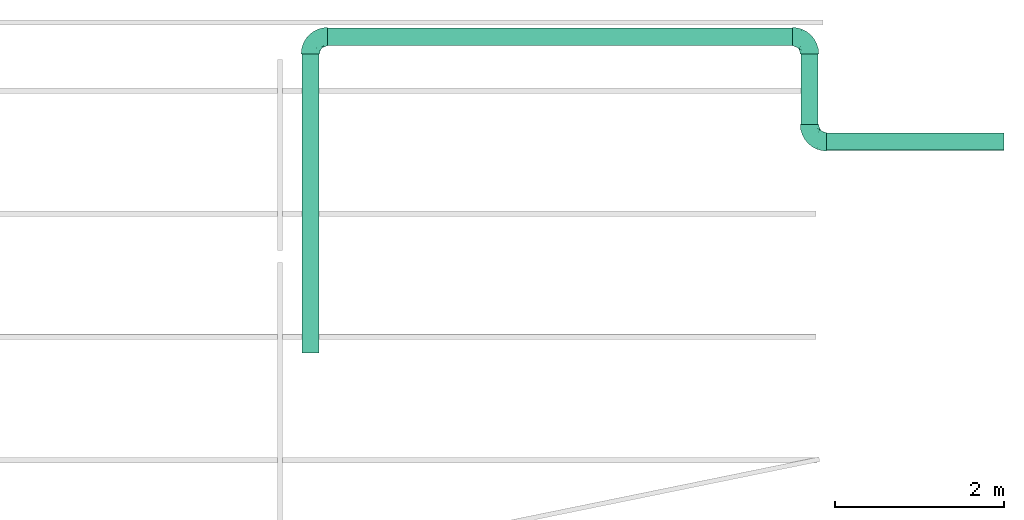
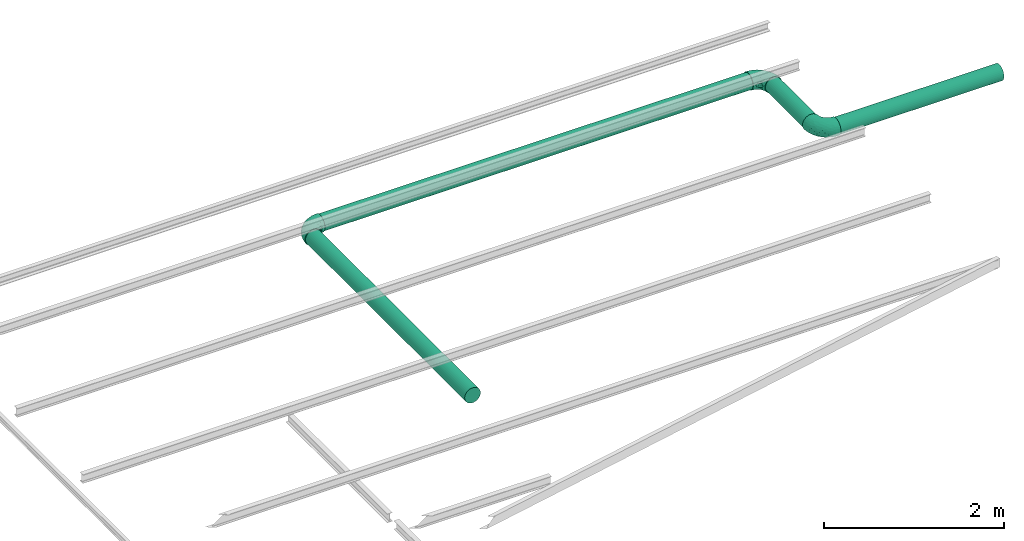
# One storey, part 2 of 2: 4 flow segments, 3 flow fittings.
"""IFC2X3 building model written with IfcOpenShell, lengths in metres."""

from ifc_helpers import new_model, entity, si_unit, converted_unit, derived_unit, direction, frame, frame_2d, origin, origin_2d_with_axis, place, context, subcontext, project, spatial, circle, extrude, faceted_brep, source, transform, mapped, material, type_object, type_shapes, element, save


model = new_model("IFC2X3")

# Units and contexts
model_context = context("Model", 3, precision=1e-05, world=origin(), true_north=direction((6.123233995736766e-17, 1.0)))
body_context = subcontext(model_context, "Body", "Model", "MODEL_VIEW")
ifc_project = project(units=[si_unit("LENGTHUNIT", "METRE"), converted_unit("PLANEANGLEUNIT", "DEGREE", entity("IfcPlaneAngleMeasure", 0.017453292519943278), si_unit("PLANEANGLEUNIT", "RADIAN"), dimensions=[0, 0, 0, 0, 0, 0, 0]), si_unit("AREAUNIT", "SQUARE_METRE"), derived_unit("THERMALTRANSMITTANCEUNIT", [(si_unit("MASSUNIT", "GRAM", prefix="KILO"), 1), (si_unit("THERMODYNAMICTEMPERATUREUNIT", "KELVIN"), -1), (si_unit("TIMEUNIT", "SECOND"), -3)])], contexts=[model_context])

# Site, building, storey
site_placement = place(None, origin())
site = spatial("IfcSite", under=ifc_project, at=site_placement, CompositionType="ELEMENT")
building_placement = place(site_placement, origin())
building = spatial("IfcBuilding", under=site, at=building_placement, CompositionType="ELEMENT")
storey_placement = place(building_placement, frame((0.0, 0.0, 8.0952)))
storey = spatial("IfcBuildingStorey", under=building, at=storey_placement, Name="2", CompositionType="ELEMENT", Elevation=8.0952)

# Flow fittings
ifc_material = material()
pipe_fitting_type = type_object("IfcPipeFittingType", Name="M_Elbow - Welded - Generic:Standard", PredefinedType="NOTDEFINED", material=ifc_material)
shared_shape = source(origin(), body_context, "Body", "Brep", [
    faceted_brep([(-0.2029999999999909, 0.05477499999999662, -0.09487308298458706), (-0.20299999999999083, 0.028353626390977812, -0.10581717426996927), (-0.20299999999999077, 0.0, -0.10955000000000187), (-0.20299999999999072, -0.028353626390984446, -0.10581717426996935), (-0.20299999999999063, -0.054775000000003286, -0.09487308298458724), (-0.2029999999999906, -0.0774635478789896, -0.07746354787898832), (-0.20299999999999055, -0.09487308298458863, -0.054775000000002114), (-0.20299999999999055, -0.10581717426997082, -0.028353626390983325), (-0.2029999999999905, -0.10955000000000349, 0.0), (-0.20299999999999055, -0.10581717426997103, 0.028353626390978905), (-0.20299999999999055, -0.09487308298458896, 0.05477499999999777), (-0.2029999999999906, -0.07746354787899007, 0.07746354787898414), (-0.20299999999999063, -0.05477500000000386, 0.09487308298458318), (-0.20299999999999072, -0.028353626390985088, 0.10581717426996545), (-0.20299999999999077, 0.0, 0.10954999999999813), (-0.20299999999999083, 0.028353626390977136, 0.10581717426996572), (-0.2029999999999909, 0.05477499999999601, 0.09487308298458369), (-0.20299999999999094, 0.07746354787898237, 0.07746354787898485), (-0.20299999999999102, 0.09487308298458146, 0.05477499999999869), (-0.20299999999999102, 0.10581717426996377, 0.028353626390979932), (-0.20299999999999105, 0.10954999999999651, 0.0), (-0.20299999999999102, 0.10581717426996395, -0.028353626390982992), (-0.20299999999999102, 0.0948730829845818, -0.05477500000000182), (-0.20299999999999094, 0.07746354787898285, -0.07746354787898808), (0.0, 0.20299999999999685, -0.10955000000000187), (-0.02835362639097223, 0.20299999999999685, -0.10581717426996927), (-0.05477499999999103, 0.20299999999999685, -0.09487308298458706), (-0.07746354787897727, 0.20299999999999685, -0.07746354787898808), (-0.09487308298457622, 0.20299999999999685, -0.05477500000000182), (-0.10581717426995838, 0.20299999999999685, -0.028353626390982992), (-0.10954999999999093, 0.20299999999999685, 0.0), (-0.10581717426995818, 0.20299999999999685, 0.028353626390979932), (-0.09487308298457586, 0.20299999999999685, 0.05477499999999869), (-0.07746354787897679, 0.20299999999999685, 0.07746354787898485), (-0.05477499999999042, 0.20299999999999685, 0.09487308298458369), (-0.028353626390971554, 0.20299999999999685, 0.10581717426996572), (0.0, 0.20299999999999685, 0.10954999999999813), (0.028353626390990674, 0.20299999999999685, 0.10581717426996545), (0.05477500000000944, 0.20299999999999685, 0.09487308298458318), (0.07746354787899565, 0.20299999999999685, 0.07746354787898414), (0.09487308298459454, 0.20299999999999685, 0.05477499999999777), (0.10581717426997661, 0.20299999999999685, 0.028353626390978905), (0.10955000000000907, 0.20299999999999685, 0.0), (0.1058171742699764, 0.20299999999999685, -0.028353626390983325), (0.09487308298459421, 0.20299999999999685, -0.054775000000002114), (0.07746354787899518, 0.20299999999999685, -0.07746354787898832), (0.054775000000008865, 0.20299999999999685, -0.09487308298458724), (0.02835362639099003, 0.20299999999999685, -0.10581717426996935), (-0.14954336534599613, -0.08594109812196467, 0.06122487702853043), (-0.1332748485934179, -0.06451053009234584, 0.0812809824910811), (-0.14202451985384973, -0.10354443939003306, 0.0), (0.03654968713032344, 0.009032001416630986, 0.030449950827569083), (-0.012005360404173467, -0.03416320570891352, 0.04119777042475203), (-0.006536439572780824, -0.038210299870239973, 0.017792975406881743), (-0.13712176066209414, -0.09701624914207488, 0.03392748184714554), (-0.17165252228780314, 0.06627696082695103, 0.08981219571601828), (-0.15718158267349175, 0.09110219162507326, 0.07254834135332555), (-0.15401983187590806, -0.01526627918710941, 0.10757760233490772), (-0.14125118859336638, 0.01563605332004179, 0.10940040359103413), (0.01800622445986464, -0.01800622445985855, 0.0), (-0.02935652366971401, -0.05687582732516366, 0.0), (-0.061929234518788887, -0.07218000882116767, 0.026753867815075917), (-0.09870531808161309, -0.08480259809411471, 0.03698720921080889), (-0.08339229321428183, -0.08575854788640594, 0.0), (0.01830308944208899, 0.011718765198519913, 0.06315625980260353), (0.054067755014369265, 0.044353715755256415, 0.046736577020376306), (0.046344781941857455, 0.0617040769539669, 0.07080172850652504), (-0.14862967307346214, -0.04230367866005426, 0.09834873968971163), (-0.05301313184407351, 0.004186385379193665, 0.09940398662161253), (-0.09888062029403047, -0.003260833049873198, 0.10589790714549342), (-0.09369360395014426, -0.028866516205253115, 0.09568748056073594), (-0.015636053231945505, 0.1412511881238548, 0.109400403603099), (0.06451052954453118, 0.13327484611978793, 0.08128098240633326), (-0.01864202606984645, 0.10250821980097136, 0.10932818856064674), (-0.04015551062957799, 0.06673830859858002, 0.10915166327007177), (0.0032608330595853318, 0.09888061959905467, 0.10589790706024133), (-0.15621887749413702, 0.04211941198732314, 0.10365367386259333), (-0.09110219156117866, 0.15718158249561864, 0.07254834149648613), (-0.16266596452996757, 0.10517220834961659, 0.050562348236739676), (-0.06969031586353369, 0.10729195529214423, 0.10241401509240382), (-0.09967793783865898, 0.08223908991914583, 0.10029461679013978), (-0.0755574991241207, 0.07555749840948059, 0.10715769317948094), (-0.1480714681732594, 0.1273973618756578, 0.0), (-0.17412236187565217, 0.11412376855221447, 0.0), (-0.15467602371553027, 0.11889483897975146, 0.027660018153370717), (-0.019068532686355742, 0.045401419964729114, 0.10229070218153763), (-0.12825060576074254, 0.12825060536698027, 0.050360412662220196), (-0.11889483912999016, 0.15467602345798834, 0.027660018145840425), (-0.13424176823698497, 0.11015680930403765, 0.06595819082041575), (-0.07531338744646457, 0.13325188549278774, 0.09324338185057503), (-0.11188359760927534, 0.11188359814902164, 0.08064845933112551), (-0.047026783353229365, -0.04859120026116534, 0.057871674300646284), (0.05687582732516968, 0.029356523669720237, 0.0), (0.08575854788641182, 0.08339229321428814, 0.0), (0.0721800098213025, 0.06192923616502968, 0.026753867263186137), (0.07293186808985862, 0.090582690387516, 0.05463617929572138), (0.08925207223055691, 0.0983535229452157, 0.021484843071041416), (0.10354443939003878, 0.14202451985385606, 0.0), (0.0970162481998457, 0.13712175699102847, 0.033927482255373474), (-0.1104180841158278, 0.13318106352524076, 0.06651894909295372), (-0.10517220842467273, 0.16266596424534535, 0.05056234831188559), (0.08594109757089159, 0.14954336249634786, 0.061224877063354034), (-0.13325188557052078, 0.0753133876580639, 0.09324338171306883), (-0.11313222281551898, 0.05156351679954166, 0.10619458259148), (0.01526627924145269, 0.15401983162849978, 0.10757760231428722), (-0.06018332865732317, -0.037929060721675706, 0.07784766738724158), (-0.09058269610565396, -0.07293187039783877, 0.05463617933055201), (-0.1273973618756521, 0.1480714681732651, 0.0), (-0.11412376855220883, 0.17412236187565797, 0.0), (-0.018799939188849958, -0.018719423672080262, 0.0687990833000079), (-0.04418810594511657, 0.11155431929070726, 0.107756483686387), (-0.06627696073580784, 0.1716525223256159, 0.08981219577216222), (-0.04211941191174917, 0.15621887702545129, 0.10365367393217853), (0.042303678536229586, 0.14862967191768964, 0.09834873962631374), (0.029766167890172508, 0.0757392327881626, 0.09012188903346316), (-0.0637434545448282, 0.023965132797378483, 0.10692970428972473), (-0.013619247027259212, 0.013619244856793737, 0.08831162894209774), (0.019060738070880087, 0.037611435566127685, 0.08088549930776383), (-0.08714662491580498, 0.03519416642446365, 0.10954618947628028), (-0.09921589573865285, 0.09065705440693701, -0.09744571968322108), (-0.11452944213531632, 0.106972317544956, -0.08218882878882855), (-0.07717005416527227, 0.1286153943486159, -0.09365776802472418), (-0.17686050692861713, 0.06586878825715571, -0.08934024788067813), (-0.11459400365784804, -0.00815353438956214, -0.1064410068872363), (-0.16306826448510267, -0.015900523668810663, -0.10779819073901184), (-0.14693225969861512, 0.014695579567415408, -0.1093554644111237), (-0.13378671735187178, 0.10968161731881562, -0.06681498573494772), (-0.1625699397061465, 0.10523809349152993, -0.050515714821781646), (-0.12825060929851598, 0.12825060271292832, -0.050360411455043726), (-0.15711282440035734, 0.041993578624217466, -0.10361035408447244), (-0.10510658234210579, 0.16276178285313625, -0.05060885297192683), (-0.15467602582776216, 0.11889483797876642, -0.02766001744683299), (-0.0643852999328137, -0.07098588457092231, -0.034262512564783104), (-0.09154716692525657, 0.15566101850096298, -0.07274547212092178), (-0.1107758048589628, 0.1331549321019424, -0.06616463209734244), (-0.11889484019420314, 0.15467602216091644, -0.02766001708599317), (-0.15963253576319575, 0.09042851938244219, -0.07223153721854358), (-0.1418287101862499, 0.07233688871004613, -0.09247904217185124), (0.009393741727066052, 0.04491231541847295, -0.09047512275671873), (0.0042555481290881105, 0.086201114695649, -0.10384184680775087), (0.025501869602312363, 0.08469607383227416, -0.09513949523962935), (0.03809922890692712, 0.006736249900857909, -0.019037874128195565), (-0.035680670989702165, -0.006236718783336948, -0.0882490554832821), (-0.08621037866531017, -0.02409523663775116, -0.09622343553523112), (-0.07162906315494738, 0.009266353806037063, -0.10505024716841646), (-0.08980867987160444, 0.02970104483279657, -0.10947731958828141), (-0.14738102316622861, -0.09865158136941461, -0.035213437078480236), (-0.17038635231548982, -0.08751535319970438, -0.06339970528548775), (-0.11262298137162274, -0.09458465322188397, -0.018328705282672955), (-0.013151170603428677, 0.16015855031431442, -0.10922921843583004), (-0.04313798143926729, 0.1499440606202098, -0.10395458288064231), (-0.14905669295816515, -0.06659425411286995, -0.08262031598504367), (-0.14199366047234488, -0.04153114858605168, -0.09796746587243158), (-0.073675341945455, -0.047771614099245914, -0.07573465126583363), (-0.1264073580575819, -0.08237945160165557, -0.05872673421130216), (-0.04609710292393087, -0.04467462373192758, -0.06218280434268396), (-0.012971195286920157, -0.01973922449308579, -0.06276668043073699), (0.09865158120222013, 0.1473810228011301, -0.035213437367846726), (0.014737935154801375, 0.1488412504100921, -0.10744497462594298), (-0.12224776820954736, 0.0376894444110432, -0.10788618014941317), (-0.10647365915618567, -0.08673260891899531, -0.03895813317534478), (-0.008665599552909752, -0.03682082296050774, -0.0288811929390789), (0.06626336742070664, 0.14599440233942554, -0.08236387253908797), (0.04359479341420668, 0.17093273321527816, -0.09957587930618086), (0.039191501603481275, 0.12736882618314138, -0.09709836482845885), (-0.06657419358477858, 0.16885771802082264, -0.09006433463402419), (0.08751535307504134, 0.1703863525859483, -0.06339970550258592), (0.07155847823123697, 0.06329240834595538, -0.031044056230936427), (-0.03272415361105762, 0.032724151068434806, -0.10281963639345232), (0.0901910691292618, 0.1022755125818123, -0.023451751240568055), (-0.025181262709938618, 0.07382831401099765, -0.10825670188447592), (-0.05283949896909247, 0.04238935826106407, -0.1082428673105781), (-0.0553540238520062, 0.06837726413778306, -0.10950344151481398), (0.06665669290233343, 0.08589829125526977, -0.061014918192632446), (0.04704042400429432, 0.04555547373449181, -0.05872372753878372), (0.047771613559640325, 0.07367534313311723, -0.07573465233602394), (-0.07819404560969953, -0.06600699251141662, -0.05700696242168605), (0.08237945131720194, 0.12640735826852756, -0.05872673473004371), (-0.02368481725651699, 0.11061329502428706, -0.10954247196928667), (-0.06166026009821864, 0.10251932539888418, -0.10547995059826389), (0.033602716789467565, 0.012663447074279084, -0.04323133239660057), (0.019463725483544133, 0.02332581957105113, -0.07154648354881304), (0.08242346546402157, 0.0985101866978566, -0.04255123742781245), (-0.09409290820569476, 0.06348502714815529, -0.10641729922092348)], [[[0, 1, 2, 3, 4, 5, 6, 7, 8, 9, 10, 11, 12, 13, 14, 15, 16, 17, 18, 19, 20, 21, 22, 23]], [[24, 25, 26, 27, 28, 29, 30, 31, 32, 33, 34, 35, 36, 37, 38, 39, 40, 41, 42, 43, 44, 45, 46, 47]], [[48, 49, 11]], [[9, 8, 50]], [[51, 52, 53]], [[54, 10, 9]], [[50, 54, 9]], [[17, 55, 56]], [[10, 48, 11]], [[14, 57, 58]], [[59, 53, 60]], [[61, 62, 63]], [[12, 11, 49]], [[64, 65, 66]], [[49, 67, 12]], [[68, 69, 70]], [[71, 36, 35]], [[72, 39, 38]], [[73, 74, 75]], [[15, 76, 16]], [[77, 33, 32]], [[15, 58, 76]], [[13, 57, 14]], [[78, 19, 18]], [[79, 80, 81]], [[82, 83, 84]], [[74, 85, 75]], [[20, 19, 84]], [[86, 87, 84]], [[51, 64, 52]], [[78, 56, 88]], [[89, 77, 90]], [[17, 16, 55]], [[18, 17, 56]], [[91, 61, 52]], [[20, 84, 83]], [[92, 93, 94]], [[95, 94, 96]], [[97, 41, 98]], [[97, 98, 96]], [[99, 100, 86]], [[30, 87, 31]], [[14, 58, 15]], [[98, 41, 40]], [[101, 72, 95]], [[40, 39, 101]], [[63, 54, 50]], [[102, 103, 80]], [[54, 62, 48]], [[41, 97, 42]], [[101, 98, 40]], [[37, 36, 104]], [[105, 49, 106]], [[87, 82, 84]], [[87, 100, 31]], [[87, 107, 82]], [[108, 87, 30]], [[60, 61, 63]], [[109, 105, 91]], [[107, 87, 108]], [[110, 74, 73]], [[34, 33, 111]], [[77, 89, 111]], [[71, 112, 110]], [[72, 113, 114]], [[113, 38, 37]], [[35, 34, 112]], [[35, 112, 71]], [[104, 71, 73]], [[12, 67, 13]], [[115, 69, 68]], [[113, 72, 38]], [[86, 100, 87]], [[59, 92, 51]], [[90, 99, 88]], [[80, 90, 102]], [[78, 86, 84]], [[94, 51, 92]], [[116, 105, 109]], [[94, 65, 51]], [[66, 72, 114]], [[91, 105, 106]], [[105, 116, 68]], [[70, 49, 105]], [[57, 67, 69]], [[104, 113, 37]], [[75, 85, 114]], [[75, 114, 113]], [[117, 64, 66]], [[111, 112, 34]], [[110, 79, 81]], [[58, 118, 103]], [[55, 76, 102]], [[54, 48, 10]], [[49, 48, 106]], [[72, 101, 39]], [[98, 101, 95]], [[99, 90, 77]], [[56, 102, 90]], [[71, 104, 36]], [[113, 104, 75]], [[67, 57, 13]], [[58, 57, 69]], [[61, 60, 53]], [[62, 61, 106]], [[96, 94, 93]], [[94, 95, 65]], [[77, 32, 100]], [[31, 100, 32]], [[19, 78, 84]], [[18, 56, 78]], [[79, 112, 89]], [[110, 81, 74]], [[118, 74, 81]], [[85, 68, 116]], [[103, 81, 80]], [[69, 118, 58]], [[118, 69, 115]], [[114, 85, 116]], [[85, 74, 115]], [[69, 67, 70]], [[49, 70, 67]], [[105, 68, 70]], [[85, 115, 68]], [[74, 118, 115]], [[112, 79, 110]], [[89, 90, 80]], [[80, 79, 89]], [[103, 102, 76]], [[58, 103, 76]], [[118, 81, 103]], [[77, 111, 33]], [[112, 111, 89]], [[76, 55, 16]], [[56, 55, 102]], [[66, 65, 95]], [[64, 51, 65]], [[72, 66, 95]], [[66, 114, 117]], [[114, 116, 117]], [[117, 116, 109]], [[51, 53, 59]], [[61, 53, 52]], [[61, 91, 106]], [[109, 52, 64]], [[52, 109, 91]], [[109, 64, 117]], [[100, 99, 77]], [[88, 99, 86]], [[78, 88, 86]], [[90, 88, 56]], [[48, 62, 106]], [[63, 62, 54]], [[97, 96, 93]], [[95, 96, 98]], [[104, 73, 75]], [[110, 73, 71]], [[119, 120, 121]], [[0, 23, 122]], [[123, 124, 125]], [[126, 127, 128]], [[1, 129, 125]], [[130, 29, 28]], [[83, 131, 20]], [[63, 132, 60]], [[131, 83, 82]], [[130, 133, 134]], [[107, 135, 82]], [[122, 136, 137]], [[138, 139, 140]], [[141, 92, 59]], [[142, 143, 144]], [[145, 123, 125]], [[146, 6, 147]], [[148, 50, 146]], [[50, 8, 7]], [[149, 150, 25]], [[151, 4, 152]], [[151, 153, 154]], [[151, 5, 4]], [[155, 142, 156]], [[23, 22, 136]], [[146, 7, 6]], [[147, 6, 5]], [[44, 43, 157]], [[4, 3, 152]], [[124, 152, 3]], [[47, 158, 24]], [[129, 159, 125]], [[131, 82, 135]], [[143, 152, 123]], [[128, 131, 135]], [[2, 1, 125]], [[29, 135, 30]], [[146, 160, 148]], [[161, 60, 132]], [[21, 131, 127]], [[150, 26, 25]], [[46, 45, 162]], [[158, 47, 163]], [[164, 163, 162]], [[27, 165, 133]], [[149, 25, 24]], [[45, 44, 166]], [[27, 26, 165]], [[30, 135, 108]], [[47, 46, 163]], [[92, 141, 167]], [[60, 161, 59]], [[138, 168, 139]], [[150, 121, 165]], [[167, 169, 93]], [[170, 171, 172]], [[173, 167, 174]], [[2, 124, 3]], [[164, 162, 175]], [[27, 133, 28]], [[42, 97, 43]], [[167, 93, 92]], [[132, 176, 155]], [[157, 177, 166]], [[137, 120, 119]], [[178, 158, 139]], [[121, 150, 179]], [[20, 131, 21]], [[1, 0, 129]], [[108, 135, 107]], [[125, 159, 145]], [[176, 132, 160]], [[178, 172, 179]], [[120, 137, 136]], [[130, 128, 135]], [[174, 180, 181]], [[157, 169, 182]], [[128, 127, 131]], [[134, 120, 126]], [[166, 162, 45]], [[162, 177, 173]], [[139, 158, 164]], [[149, 158, 178]], [[140, 175, 138]], [[170, 172, 178]], [[43, 97, 157]], [[97, 93, 169]], [[146, 154, 160]], [[50, 7, 146]], [[126, 120, 136]], [[133, 121, 120]], [[161, 132, 155]], [[141, 161, 180]], [[122, 129, 0]], [[183, 129, 137]], [[153, 151, 152]], [[147, 151, 154]], [[181, 180, 156]], [[142, 168, 138]], [[138, 175, 181]], [[153, 152, 143]], [[181, 142, 138]], [[161, 156, 180]], [[172, 145, 183]], [[145, 171, 144]], [[29, 130, 135]], [[28, 133, 130]], [[136, 22, 127]], [[21, 127, 22]], [[158, 149, 24]], [[150, 149, 178]], [[179, 172, 183]], [[178, 139, 170]], [[179, 183, 119]], [[178, 179, 150]], [[143, 123, 144]], [[153, 143, 142]], [[181, 175, 174]], [[142, 181, 156]], [[150, 165, 26]], [[133, 165, 121]], [[125, 124, 2]], [[152, 124, 123]], [[179, 119, 121]], [[137, 119, 183]], [[139, 168, 170]], [[171, 170, 168]], [[144, 171, 168]], [[145, 172, 171]], [[144, 168, 142]], [[145, 144, 123]], [[173, 174, 175]], [[167, 180, 174]], [[162, 173, 175]], [[173, 177, 182]], [[161, 141, 59]], [[167, 141, 180]], [[136, 122, 23]], [[129, 122, 137]], [[162, 163, 46]], [[158, 163, 164]], [[157, 166, 44]], [[162, 166, 177]], [[151, 147, 5]], [[146, 147, 154]], [[154, 153, 176]], [[155, 176, 153]], [[142, 155, 153]], [[161, 155, 156]], [[182, 169, 167]], [[97, 169, 157]], [[173, 182, 167]], [[157, 182, 177]], [[176, 160, 154]], [[148, 132, 63]], [[132, 148, 160]], [[50, 148, 63]], [[127, 126, 136]], [[134, 126, 128]], [[130, 134, 128]], [[120, 134, 133]], [[129, 183, 159]], [[145, 159, 183]], [[139, 164, 140]], [[175, 140, 164]]]),
])
type_shapes(pipe_fitting_type, [shared_shape])
for number, where, z_axis, x_axis, name in (
    (1, (9.65149713519211, 4.299661947741469, 0.5943339766339276), (0.0, 0.0, 1.0), (-1.0, 0.0, 0.0), "M_Elbow - Welded - Generic:Standard"),
    (2, (15.551982757982861, 4.299661947741467, 0.5943339766339276), (0.0, 0.0, 1.0), (0.0, 1.0, 0.0), "M_Elbow - Welded - Generic:Standard"),
    (3, (15.551982757982888, 3.056524543618064, 0.5943339766339276), (0.0, 0.0, 1.0), (0.0, -1.0, 0.0), "M_Elbow - Welded - Generic:Standard"),
):
    element("IfcFlowFitting", number, at=place(storey_placement, frame(where, z_axis=z_axis, x_axis=x_axis)), inside=storey, type_object=pipe_fitting_type, material=ifc_material, Name=name, ObjectType="M_Elbow - Welded - Generic:Standard", context=body_context, shape_type="MappedRepresentation", body=[
        mapped(shared_shape, transform((0.0, 0.0, 0.0), scale=1.0)),
    ])

# Flow segments
pipe_segment_type = type_object("IfcPipeSegmentType", Name="Pipe Types:Standard", PredefinedType="NOTDEFINED")
flow_segment_1_placement = place(storey_placement, frame((9.54830186295618, 0.559524543618058, 0.6975292488698415)))
element("IfcFlowSegment", 4, at=flow_segment_1_placement, inside=storey, type_object=pipe_segment_type, Name="Pipe Types:Standard", ObjectType="Pipe Types:Standard", context=body_context, shape_type="SweptSolid", body=[
    extrude(circle(Radius=0.1016, at=origin_2d_with_axis()), frame((0.10319527223591554, 0.0, -0.10319527223591554), z_axis=(0.0, 1.0, 0.0), x_axis=(1.0, 0.0, 0.0)), (0.0, 0.0, 1.0), 3.537137404123422),
])
flow_segment_2_placement = place(storey_placement, frame((9.854497135192096, 4.196466675505564, 0.49113870439800955)))
element("IfcFlowSegment", 5, at=flow_segment_2_placement, inside=storey, type_object=pipe_segment_type, Name="Pipe Types:Standard", ObjectType="Pipe Types:Standard", context=body_context, shape_type="SweptSolid", body=[
    extrude(circle(Radius=0.1016, at=origin_2d_with_axis()), frame((0.0, 0.10319527223591608, 0.10319527223591554), z_axis=(1.0, 0.0, 0.0), x_axis=(0.0, -1.0, 0.0)), (0.0, 0.0, 1.0), 5.494485622790778),
])
flow_segment_3_placement = place(storey_placement, frame((15.448787485746958, 3.2595245436180473, 0.49113870439800955)))
element("IfcFlowSegment", 6, at=flow_segment_3_placement, inside=storey, type_object=pipe_segment_type, Name="Pipe Types:Standard", ObjectType="Pipe Types:Standard", context=body_context, shape_type="SweptSolid", body=[
    extrude(circle(Radius=0.1016, at=frame_2d((0.0, 1.0828671292983927e-15), x_axis=(1.0, 0.0))), frame((0.10319527223591662, 0.0, 0.10319527223591446), z_axis=(0.0, 1.0, 0.0), x_axis=(-1.0, 0.0, 0.0)), (0.0, 0.0, 1.0), 0.8371374041234346),
])
flow_segment_4_placement = place(storey_placement, frame((15.754982757982877, 2.953329271382132, 0.49113870439800955)))
element("IfcFlowSegment", 7, at=flow_segment_4_placement, inside=storey, type_object=pipe_segment_type, Name="Pipe Types:Standard", ObjectType="Pipe Types:Standard", context=body_context, shape_type="SweptSolid", body=[
    extrude(circle(Radius=0.1016, at=frame_2d((5.414335646491964e-16, -2.888882129619489e-46), x_axis=(1.0, 0.0))), frame((0.0, 0.10319527223591662, 0.10319527223591554), z_axis=(1.0, 0.0, 0.0), x_axis=(0.0, -1.0, 0.0)), (0.0, 0.0, 1.0), 2.096514377209227),
])

save(model, "model.ifc")
